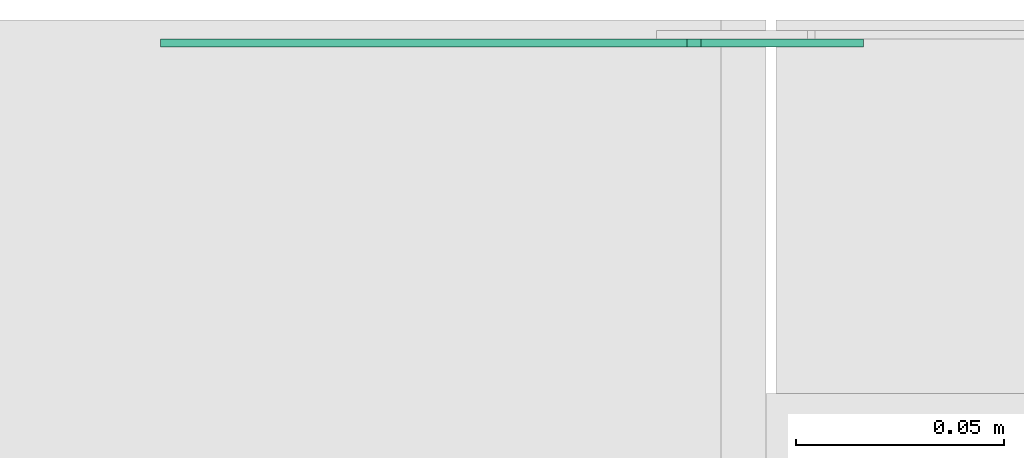
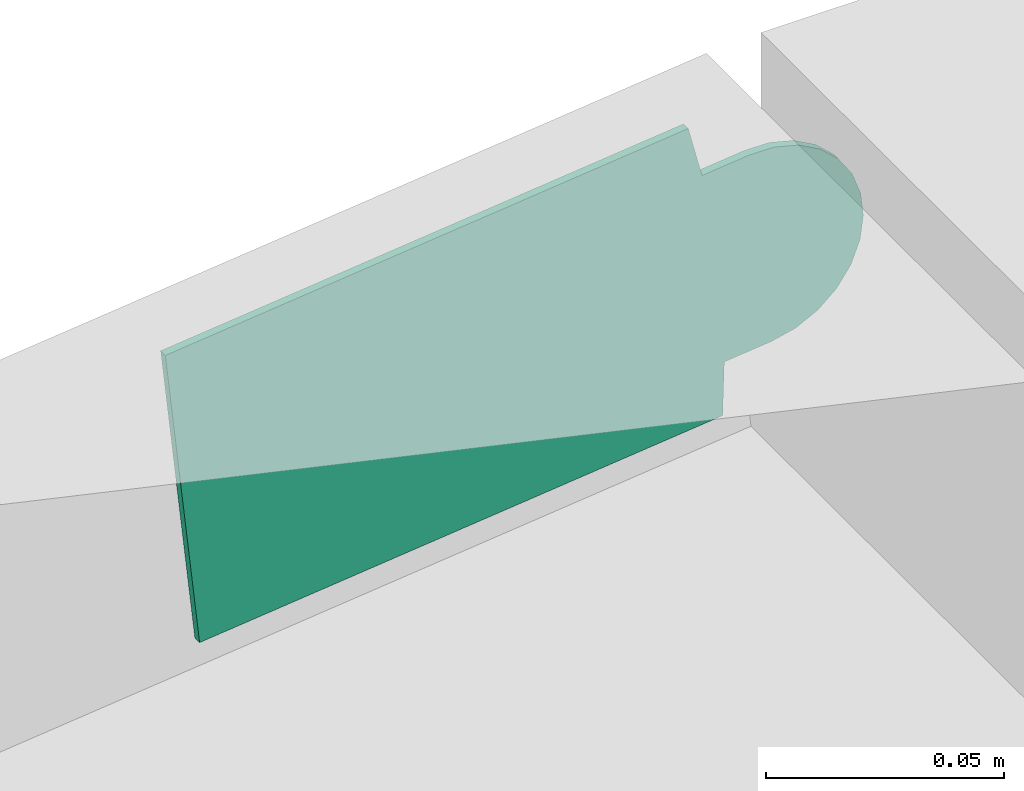
# One storey, part 16 of 23: 1 flow fitting.
"""IFC2X3 building model written with IfcOpenShell, lengths in millimetres."""

from ifc_helpers import new_model, entity, si_unit, converted_unit, derived_unit, direction, frame, frame_2d, origin, place, context, subcontext, project, spatial, polyline, circle_curve, parameter, trimmed, segment, composite_curve, outline, extrude, source, transform, mapped, material, type_object, type_shapes, element, save


model = new_model("IFC2X3")

# Units and contexts
model_context = context("Model", 3, precision=0.01, world=origin(), true_north=direction((6.12303176911189e-17, 1.0)))
body_context = subcontext(model_context, "Body", "Model", "MODEL_VIEW")
ifc_project = project(units=[si_unit("LENGTHUNIT", "METRE", prefix="MILLI"), si_unit("AREAUNIT", "SQUARE_METRE"), si_unit("VOLUMEUNIT", "CUBIC_METRE"), converted_unit("PLANEANGLEUNIT", "DEGREE", entity("IfcRatioMeasure", 0.0174532925199433), si_unit("PLANEANGLEUNIT", "RADIAN"), dimensions=[0, 0, 0, 0, 0, 0, 0]), si_unit("MASSUNIT", "GRAM", prefix="KILO"), derived_unit("MASSDENSITYUNIT", [(si_unit("MASSUNIT", "GRAM", prefix="KILO"), 1), (si_unit("LENGTHUNIT", "METRE"), -3)]), derived_unit("MOMENTOFINERTIAUNIT", [(si_unit("LENGTHUNIT", "METRE"), 4)]), si_unit("TIMEUNIT", "SECOND"), si_unit("FREQUENCYUNIT", "HERTZ"), si_unit("THERMODYNAMICTEMPERATUREUNIT", "DEGREE_CELSIUS"), derived_unit("THERMALTRANSMITTANCEUNIT", [(si_unit("MASSUNIT", "GRAM", prefix="KILO"), 1), (si_unit("THERMODYNAMICTEMPERATUREUNIT", "KELVIN"), -1), (si_unit("TIMEUNIT", "SECOND"), -3)]), derived_unit("VOLUMETRICFLOWRATEUNIT", [(si_unit("LENGTHUNIT", "METRE"), 3), (si_unit("TIMEUNIT", "SECOND"), -1)]), derived_unit("MASSFLOWRATEUNIT", [(si_unit("MASSUNIT", "GRAM", prefix="KILO"), 1), (si_unit("TIMEUNIT", "SECOND"), -1)]), derived_unit("ROTATIONALFREQUENCYUNIT", [(si_unit("TIMEUNIT", "SECOND"), -1)]), si_unit("ELECTRICCURRENTUNIT", "AMPERE"), si_unit("ELECTRICVOLTAGEUNIT", "VOLT"), si_unit("POWERUNIT", "WATT"), si_unit("FORCEUNIT", "NEWTON", prefix="KILO"), si_unit("ILLUMINANCEUNIT", "LUX"), si_unit("LUMINOUSFLUXUNIT", "LUMEN"), si_unit("LUMINOUSINTENSITYUNIT", "CANDELA"), derived_unit("USERDEFINED", [(si_unit("MASSUNIT", "GRAM", prefix="KILO"), -1), (si_unit("LENGTHUNIT", "METRE"), -2), (si_unit("TIMEUNIT", "SECOND"), 3), (si_unit("LUMINOUSFLUXUNIT", "LUMEN"), 1)]), derived_unit("LINEARVELOCITYUNIT", [(si_unit("LENGTHUNIT", "METRE"), 1), (si_unit("TIMEUNIT", "SECOND"), -1)]), si_unit("PRESSUREUNIT", "PASCAL"), derived_unit("USERDEFINED", [(si_unit("LENGTHUNIT", "METRE"), -2), (si_unit("MASSUNIT", "GRAM", prefix="KILO"), 1), (si_unit("TIMEUNIT", "SECOND"), -2)]), derived_unit("LINEARFORCEUNIT", [(si_unit("MASSUNIT", "GRAM", prefix="KILO"), 1), (si_unit("LENGTHUNIT", "METRE"), 1), (si_unit("TIMEUNIT", "SECOND"), -2), (si_unit("LENGTHUNIT", "METRE"), -1)]), derived_unit("PLANARFORCEUNIT", [(si_unit("MASSUNIT", "GRAM", prefix="KILO"), 1), (si_unit("LENGTHUNIT", "METRE"), 1), (si_unit("TIMEUNIT", "SECOND"), -2), (si_unit("LENGTHUNIT", "METRE"), -2)])], contexts=[model_context])

# Site, building, storey
site_placement = place(None, origin())
site = spatial("IfcSite", under=ifc_project, at=site_placement, CompositionType="ELEMENT")
building_placement = place(site_placement, origin())
building = spatial("IfcBuilding", under=site, at=building_placement, CompositionType="ELEMENT")
storey_placement = place(building_placement, frame((0.0, 0.0, 24000.0)))
storey = spatial("IfcBuildingStorey", under=building, at=storey_placement, CompositionType="ELEMENT", Elevation=24000.0)

# Flow fitting
ifc_material = material(Name="G")
cable_carrier_fitting_type = type_object("IfcCableCarrierFittingType", PredefinedType="NOTDEFINED", material=ifc_material)
shared_shape = source(origin(), body_context, "Body", "SweptSolid", [
    extrude(outline(composite_curve([segment(trimmed(circle_curve(frame_2d((-41.47, 0.0), x_axis=(1.0, 0.0)), 25.0), [parameter(90.0000000000007)], [parameter(270.0)], True, "PARAMETER"), True, "CONTINUOUS"), segment(polyline([(-41.47, -25.0), (-29.97, -25.0)]), True, "CONTINUOUS"), segment(polyline([(-29.97, -25.0), (-28.1, -38.5)]), True, "CONTINUOUS"), segment(polyline([(-28.1, -38.5), (99.53, -38.5)]), True, "CONTINUOUS"), segment(polyline([(99.53, -38.5), (99.53, 38.5)]), True, "CONTINUOUS"), segment(polyline([(99.53, 38.5), (-28.1, 38.5)]), True, "CONTINUOUS"), segment(polyline([(-28.1, 38.5), (-29.97, 25.0)]), True, "CONTINUOUS"), segment(polyline([(-29.97, 25.0), (-41.47, 25.0)]), True, "CONTINUOUS")], self_intersect=False)), frame((41.47, 0.0, 0.0)), (0.0, 0.0, 1.0), 2.0),
])
type_shapes(cable_carrier_fitting_type, [shared_shape])
flow_fitting_placement = place(storey_placement, frame((42728.48, 19103.46, 3295.4), z_axis=(0.0, 1.0, 0.0), x_axis=(-0.99415015149761, 0.0, -0.10800683440079)))
element("IfcFlowFitting", 1, at=flow_fitting_placement, inside=storey, type_object=cable_carrier_fitting_type, material=ifc_material, context=body_context, shape_type="MappedRepresentation", body=[
    mapped(shared_shape, transform((0.0, 0.0, 0.0), scale=1.0)),
])

save(model, "model.ifc")
